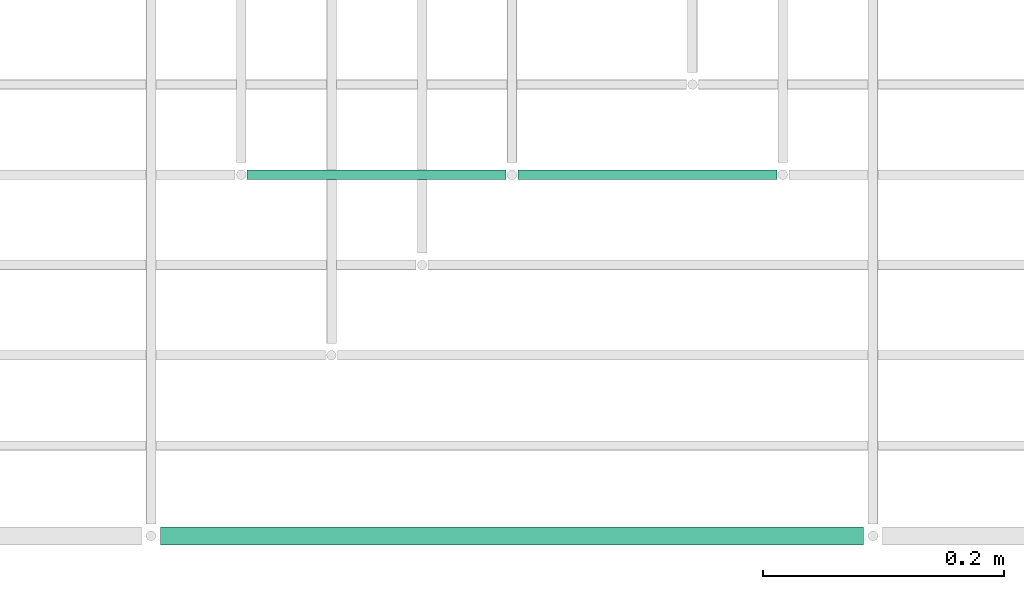
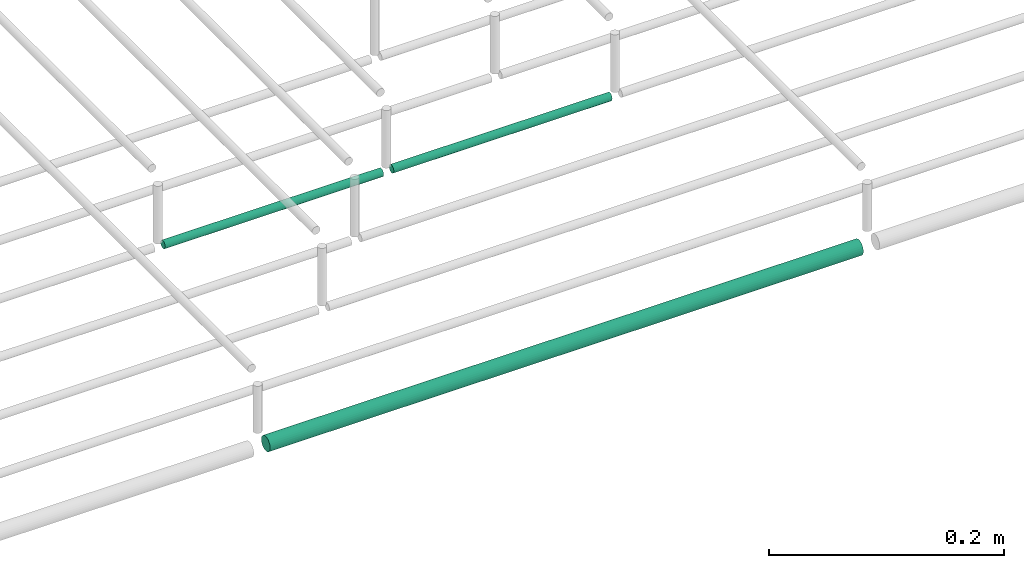
# One storey, part 46 of 89: 3 flow segments.
"""IFC2X3 building model written with IfcOpenShell, lengths in millimetres."""

from ifc_helpers import new_model, entity, si_unit, converted_unit, derived_unit, direction, frame, frame_2d, origin, origin_2d_with_axis, place, context, subcontext, project, spatial, circle, extrude, type_object, element, save


model = new_model("IFC2X3")

# Units and contexts
model_context = context("Model", 3, precision=0.01, world=origin(), true_north=direction((6.12303176911189e-17, 1.0)))
body_context = subcontext(model_context, "Body", "Model", "MODEL_VIEW")
ifc_project = project(units=[si_unit("LENGTHUNIT", "METRE", prefix="MILLI"), si_unit("AREAUNIT", "SQUARE_METRE"), si_unit("VOLUMEUNIT", "CUBIC_METRE"), converted_unit("PLANEANGLEUNIT", "DEGREE", entity("IfcRatioMeasure", 0.0174532925199433), si_unit("PLANEANGLEUNIT", "RADIAN"), dimensions=[0, 0, 0, 0, 0, 0, 0]), si_unit("MASSUNIT", "GRAM", prefix="KILO"), derived_unit("MASSDENSITYUNIT", [(si_unit("MASSUNIT", "GRAM", prefix="KILO"), 1), (si_unit("LENGTHUNIT", "METRE"), -3)]), derived_unit("MOMENTOFINERTIAUNIT", [(si_unit("LENGTHUNIT", "METRE"), 4)]), si_unit("TIMEUNIT", "SECOND"), si_unit("FREQUENCYUNIT", "HERTZ"), si_unit("THERMODYNAMICTEMPERATUREUNIT", "DEGREE_CELSIUS"), derived_unit("THERMALTRANSMITTANCEUNIT", [(si_unit("MASSUNIT", "GRAM", prefix="KILO"), 1), (si_unit("THERMODYNAMICTEMPERATUREUNIT", "KELVIN"), -1), (si_unit("TIMEUNIT", "SECOND"), -3)]), derived_unit("VOLUMETRICFLOWRATEUNIT", [(si_unit("LENGTHUNIT", "METRE"), 3), (si_unit("TIMEUNIT", "SECOND"), -1)]), derived_unit("MASSFLOWRATEUNIT", [(si_unit("MASSUNIT", "GRAM", prefix="KILO"), 1), (si_unit("TIMEUNIT", "SECOND"), -1)]), derived_unit("ROTATIONALFREQUENCYUNIT", [(si_unit("TIMEUNIT", "SECOND"), -1)]), si_unit("ELECTRICCURRENTUNIT", "AMPERE"), si_unit("ELECTRICVOLTAGEUNIT", "VOLT"), si_unit("POWERUNIT", "WATT"), si_unit("FORCEUNIT", "NEWTON", prefix="KILO"), si_unit("ILLUMINANCEUNIT", "LUX"), si_unit("LUMINOUSFLUXUNIT", "LUMEN"), si_unit("LUMINOUSINTENSITYUNIT", "CANDELA"), derived_unit("USERDEFINED", [(si_unit("MASSUNIT", "GRAM", prefix="KILO"), -1), (si_unit("LENGTHUNIT", "METRE"), -2), (si_unit("TIMEUNIT", "SECOND"), 3), (si_unit("LUMINOUSFLUXUNIT", "LUMEN"), 1)]), derived_unit("LINEARVELOCITYUNIT", [(si_unit("LENGTHUNIT", "METRE"), 1), (si_unit("TIMEUNIT", "SECOND"), -1)]), si_unit("PRESSUREUNIT", "PASCAL"), derived_unit("USERDEFINED", [(si_unit("LENGTHUNIT", "METRE"), -2), (si_unit("MASSUNIT", "GRAM", prefix="KILO"), 1), (si_unit("TIMEUNIT", "SECOND"), -2)]), derived_unit("LINEARFORCEUNIT", [(si_unit("MASSUNIT", "GRAM", prefix="KILO"), 1), (si_unit("LENGTHUNIT", "METRE"), 1), (si_unit("TIMEUNIT", "SECOND"), -2), (si_unit("LENGTHUNIT", "METRE"), -1)]), derived_unit("PLANARFORCEUNIT", [(si_unit("MASSUNIT", "GRAM", prefix="KILO"), 1), (si_unit("LENGTHUNIT", "METRE"), 1), (si_unit("TIMEUNIT", "SECOND"), -2), (si_unit("LENGTHUNIT", "METRE"), -2)])], contexts=[model_context])

# Site, building, storey
site_placement = place(None, frame((0.0, -0.00077364408347762, 0.0)))
site = spatial("IfcSite", under=ifc_project, at=site_placement, CompositionType="ELEMENT")
building_placement = place(site_placement, origin())
building = spatial("IfcBuilding", under=site, at=building_placement, CompositionType="ELEMENT")
storey_placement = place(building_placement, frame((0.0, 0.0, 24000.0)))
storey = spatial("IfcBuildingStorey", under=building, at=storey_placement, CompositionType="ELEMENT", Elevation=24000.0)

# Flow segments
pipe_segment_type = type_object("IfcPipeSegmentType", PredefinedType="NOTDEFINED")
flow_segment_1_placement = place(storey_placement, frame((53071.1933873496, 1469.35602729995, 2994.40472776409)))
element("IfcFlowSegment", 1, at=flow_segment_1_placement, inside=storey, type_object=pipe_segment_type, context=body_context, shape_type="SweptSolid", body=[
    extrude(circle(Radius=4.0, at=frame_2d((-5.41433564649196e-13, 0.0), x_axis=(1.0, 0.0))), frame((0.0, 5.59527223591634, 5.59527223591499), z_axis=(1.0, 0.0, 0.0), x_axis=(0.0, 1.0, 0.0)), (0.0, 0.0, 1.0), 215.000000000012),
])
flow_segment_2_placement = place(storey_placement, frame((53296.1933873496, 1469.35602729995, 2994.40472776409)))
element("IfcFlowSegment", 2, at=flow_segment_2_placement, inside=storey, type_object=pipe_segment_type, context=body_context, shape_type="SweptSolid", body=[
    extrude(circle(Radius=4.0, at=origin_2d_with_axis()), frame((0.0, 5.5952722359158, 5.59527223591499), z_axis=(1.0, 0.0, 0.0), x_axis=(0.0, 1.0, 0.0)), (0.0, 0.0, 1.0), 215.000000000003),
])
flow_segment_3_placement = place(storey_placement, frame((52999.1933873496, 1165.8560272999, 2990.90472776408)))
element("IfcFlowSegment", 3, at=flow_segment_3_placement, inside=storey, type_object=pipe_segment_type, context=body_context, shape_type="SweptSolid", body=[
    extrude(circle(Radius=7.5, at=frame_2d((-1.35358391162299e-13, 0.0), x_axis=(1.0, 0.0))), frame((0.0, 9.09527223591582, 9.09527223591419), z_axis=(1.0, 0.0, 0.0), x_axis=(0.0, -1.0, 0.0)), (0.0, 0.0, 1.0), 584.000000000015),
])

save(model, "model.ifc")
